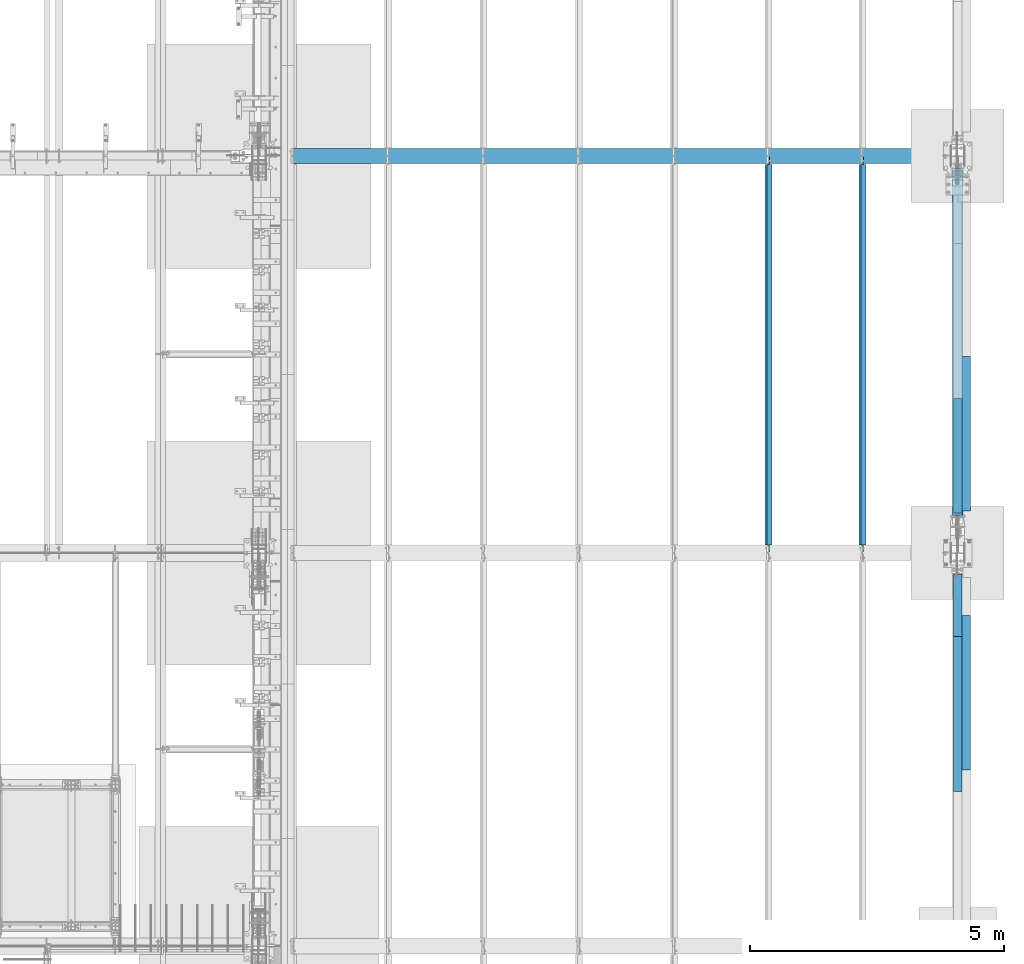
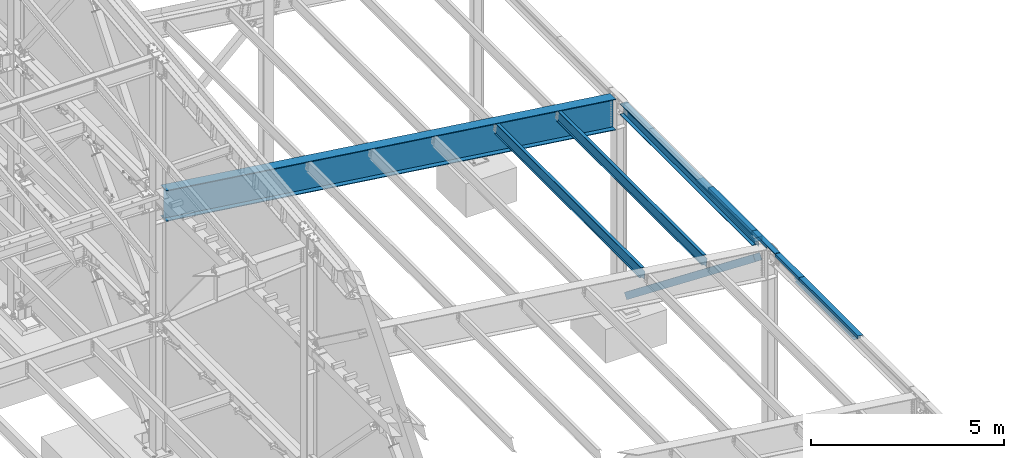
# One storey, part 750 of 1179: 10 beams, 1 member, 7 elements without a shape of their own.
"""IFC2X3 building model written with IfcOpenShell, lengths in millimetres."""

from ifc_helpers import new_model, si_unit, frame, origin_with_axes, place, context, subcontext, project, spatial, faceted_brep, material, type_object, element, aggregate, save


model = new_model("IFC2X3")

# Units and contexts
model_context = context("Model", 3, precision=1e-05, world=origin_with_axes())
body_context = subcontext(model_context, "Body", "Model", "MODEL_VIEW")
ifc_project = project(units=[si_unit("LENGTHUNIT", "METRE", prefix="MILLI"), si_unit("AREAUNIT", "SQUARE_METRE"), si_unit("VOLUMEUNIT", "CUBIC_METRE"), si_unit("MASSUNIT", "GRAM", prefix="KILO"), si_unit("TIMEUNIT", "SECOND"), si_unit("PLANEANGLEUNIT", "RADIAN"), si_unit("SOLIDANGLEUNIT", "STERADIAN"), si_unit("THERMODYNAMICTEMPERATUREUNIT", "DEGREE_CELSIUS"), si_unit("LUMINOUSINTENSITYUNIT", "LUMEN")], contexts=[model_context])

# Site, building, storey
site_placement = place(None, origin_with_axes())
site = spatial("IfcSite", under=ifc_project, at=site_placement, CompositionType="ELEMENT")
building_placement = place(site_placement, origin_with_axes())
building = spatial("IfcBuilding", under=site, at=building_placement, Name="Undefined", CompositionType="ELEMENT")
storey_placement = place(building_placement, origin_with_axes())
storey = spatial("IfcBuildingStorey", under=building, at=storey_placement, Name="Undefined", CompositionType="ELEMENT", Elevation=0.0)

# Assembly, beam
assembly_1_placement = place(storey_placement, origin_with_axes())
assembly_1 = element("IfcElementAssembly", 1, at=assembly_1_placement, inside=storey, Name="BENT_PLATE", AssemblyPlace="NOTDEFINED", PredefinedType="RIGID_FRAME")
ifc_material_1 = material(Name="STEEL/A36")
beam_type_1 = type_object("IfcBeamType", PredefinedType="NOTDEFINED")
beam_1_placement = place(assembly_1_placement, frame((37996.8124994167, 19419.1191790178, 6096.00000000004), z_axis=(0.0, -1.0, 0.0), x_axis=(0.0, 0.0, 1.0)))
beam_1 = element("IfcBeam", 2, at=beam_1_placement, type_object=beam_type_1, material=ifc_material_1, Name="BENT_PLATE", context=body_context, shape_type="Brep", body=[
    faceted_brep([(60.3249999999616, -160.337506103519, 173.062929017837), (60.3249999999616, -150.812506103524, 173.062929017837), (-7.6397554948926e-11, -150.812506103524, 173.062929017837), (-7.6397554948926e-11, -160.337506103519, 173.062929017837), (60.3249999999616, -160.337506103519, 584.200000000001), (60.3249999999616, -150.812506103524, 584.200000000001), (60.3249999999616, -4.76249999951688, 173.062929017837), (60.3249999999616, 4.76250000048458, 173.062929017837), (-3.8198777474463e-11, 4.76249999999709, 173.062929017837), (3.8198777474463e-11, -4.76249999999709, 173.062929017837), (60.3249999999616, -4.76249999951688, 584.200000000001), (60.3249999999616, 4.76250000048458, 584.200000000001), (62.266532833075, -150.812506103524, -584.200000000001), (81.9873102930469, -4.76249999933498, -584.200000000001), (3.8198777474463e-11, -4.76249999999709, -584.200000000001), (-3.8198777474463e-11, 4.76249999999709, -584.200000000001), (92.8848876952779, 4.76250000074651, -584.200000000001), (70.5918350219381, -160.337506103519, -584.200000000001), (-7.6397554948926e-11, -160.337506103519, -584.200000000001), (-7.6397554948926e-11, -150.812506103524, -584.200000000001), (62.266532833075, -150.812506103524, 584.200000000001), (81.9873102930469, -4.76249999933498, 584.200000000001), (92.8848876952779, 4.76250000074651, 584.200000000001), (70.5918350219381, -160.337506103519, 584.200000000001)], [[[0, 1, 2, 3]], [[4, 5, 1, 0]], [[6, 7, 8, 9]], [[10, 11, 7, 6]], [[12, 13, 14, 15, 16, 17, 18, 19]], [[19, 18, 3, 2]], [[20, 12, 19, 2, 1, 5]], [[21, 13, 12, 20]], [[9, 14, 13, 21, 10, 6]], [[15, 14, 9, 8]], [[22, 16, 15, 8, 7, 11]], [[16, 22, 23, 17]], [[3, 18, 17, 23, 4, 0]], [[23, 22, 11, 10, 21, 20, 5, 4]]]),
])
aggregate(assembly_1, [beam_1])

assembly_2_placement = place(storey_placement, origin_with_axes())
assembly_2 = element("IfcElementAssembly", 3, at=assembly_2_placement, inside=storey, Name="BEAM", AssemblyPlace="NOTDEFINED", PredefinedType="RIGID_FRAME")
beam_2_placement = place(assembly_2_placement, frame((37996.8124994166, 21146.3191790178, 6096.00000000004), z_axis=(0.0, -1.0, 0.0), x_axis=(0.0, 0.0, 1.0)))
beam_2 = element("IfcBeam", 4, at=beam_2_placement, type_object=beam_type_1, material=ifc_material_1, Name="BENT_PLATE", context=body_context, shape_type="Brep", body=[
    faceted_brep([(3.8198777474463e-11, -4.76249999999709, -1130.3), (3.8198777474463e-11, -4.76249999999709, 1130.3), (-3.8198777474463e-11, 4.76249999999709, 1130.3), (-3.8198777474463e-11, 4.76249999999709, -1130.3), (92.8848876952779, 4.76250000074651, 1130.3), (92.8848876952779, 4.76250000074651, -1130.3), (81.9873102930469, -4.76249999933498, -1130.3), (81.9873102930469, -4.76249999933498, 1130.3), (70.5918350219381, -160.337506103519, 1130.3), (70.5918350219381, -160.337506103519, -1130.3), (62.266532833075, -150.812506103524, -1130.3), (62.266532833075, -150.812506103524, 1130.3), (-7.6397554948926e-11, -160.337506103519, 1130.3), (-7.6397554948926e-11, -160.337506103519, -1130.3), (-7.6397554948926e-11, -150.812506103524, 1130.3), (-7.6397554948926e-11, -150.812506103524, -1130.3)], [[[0, 1, 2, 3]], [[3, 2, 4, 5]], [[1, 0, 6, 7]], [[5, 4, 8, 9]], [[7, 6, 10, 11]], [[9, 8, 12, 13]], [[8, 4, 2, 1, 7, 11, 14, 12]], [[11, 10, 15, 14]], [[10, 6, 0, 3, 5, 9, 13, 15]], [[14, 15, 13, 12]]]),
])

# Assembly, beams
assembly_3_placement = place(storey_placement, origin_with_axes())
assembly_3 = element("IfcElementAssembly", 5, at=assembly_3_placement, inside=storey, Name="BEAM", AssemblyPlace="NOTDEFINED", PredefinedType="RIGID_FRAME")
beam_3_placement = place(assembly_3_placement, frame((37996.8124994166, 18199.1, 6096.00000000004), z_axis=(0.0, -1.0, 0.0), x_axis=(0.0, 0.0, 1.0)))
beam_3 = element("IfcBeam", 6, at=beam_3_placement, type_object=beam_type_1, material=ifc_material_1, Name="BENT_PLATE", context=body_context, shape_type="Brep", body=[
    faceted_brep([(3.8198777474463e-11, -4.76249999999709, -619.125), (3.8198777474463e-11, -4.76249999999709, 619.125), (-3.8198777474463e-11, 4.76249999999709, 619.125), (-3.8198777474463e-11, 4.76249999999709, -619.125), (92.8848876952779, 4.76250000074651, 619.125), (92.8848876952779, 4.76250000074651, -619.125), (81.9873102930469, -4.76249999933498, -619.125), (81.9873102930469, -4.76249999933498, 619.125), (70.5918350219381, -160.337506103519, 619.125), (70.5918350219381, -160.337506103519, -619.125), (62.266532833075, -150.812506103524, -619.125), (62.266532833075, -150.812506103524, 619.125), (-7.6397554948926e-11, -160.337506103519, 619.125), (-7.6397554948926e-11, -160.337506103519, -619.125), (-7.6397554948926e-11, -150.812506103524, 619.125), (-7.6397554948926e-11, -150.812506103524, -619.125)], [[[0, 1, 2, 3]], [[3, 2, 4, 5]], [[1, 0, 6, 7]], [[5, 4, 8, 9]], [[7, 6, 10, 11]], [[9, 8, 12, 13]], [[8, 4, 2, 1, 7, 11, 14, 12]], [[11, 10, 15, 14]], [[10, 6, 0, 3, 5, 9, 13, 15]], [[14, 15, 13, 12]]]),
])
beam_4_placement = place(assembly_3_placement, frame((37996.8124994166, 16055.975, 6096.00000000004), z_axis=(0.0, -1.0, 0.0), x_axis=(0.0, 0.0, 1.0)))
beam_4 = element("IfcBeam", 7, at=beam_4_placement, type_object=beam_type_1, material=ifc_material_1, Name="BENT_PLATE", context=body_context, shape_type="Brep", body=[
    faceted_brep([(-2.91038304567337e-11, -4.76250000000073, -1524.0), (-2.91038304567337e-11, -4.76250000000073, 1524.0), (2.91038304567337e-11, 4.76250000000073, 1524.0), (2.91038304567337e-11, 4.76250000000073, -1524.0), (92.8848876952779, 4.76250000074651, 1524.0), (92.8848876952779, 4.76250000074651, -1524.0), (81.9873102930469, -4.76249999933498, -1524.0), (81.9873102930469, -4.76249999933498, 1524.0), (70.5918350219381, -160.337506103519, 1524.0), (70.5918350219381, -160.337506103519, -1524.0), (62.266532833075, -150.812506103524, -1524.0), (62.266532833075, -150.812506103524, 1524.0), (-7.6397554948926e-11, -160.337506103519, 1524.0), (-7.6397554948926e-11, -160.337506103519, -1524.0), (8.54161044117063e-08, -150.812499999749, 1524.0), (8.54161044117063e-08, -150.812499999749, -1524.0)], [[[0, 1, 2, 3]], [[3, 2, 4, 5]], [[1, 0, 6, 7]], [[5, 4, 8, 9]], [[7, 6, 10, 11]], [[9, 8, 12, 13]], [[8, 4, 2, 1, 7, 11, 14, 12]], [[11, 10, 15, 14]], [[10, 6, 0, 3, 5, 9, 13, 15]], [[14, 15, 13, 12]]]),
])

# Assembly, member
assembly_4_placement = place(storey_placement, origin_with_axes())
assembly_4 = element("IfcElementAssembly", 8, at=assembly_4_placement, inside=storey, Name="None", AssemblyPlace="NOTDEFINED", PredefinedType="RIGID_FRAME")
ifc_material_2 = material(Name="STEEL/A992")
member_type = type_object("IfcMemberType", Name="HSS8X8X3/16", PredefinedType="NOTDEFINED")
member_placement = place(assembly_4_placement, frame((38074.6, 26521.5643718268, 187.492569083372), z_axis=(-1.0, 0.0, 0.0), x_axis=(0.0, -0.786240824587351, 0.61792019367569)))
member = element("IfcMember", 9, at=member_placement, type_object=member_type, material=ifc_material_2, Name="None", ObjectType="HSS8X8X3/16", context=body_context, shape_type="Brep", body=[
    faceted_brep([(-3.63797880709171e-12, 96.8374999999978, -96.8375000000015), (-3.63797880709171e-12, -96.8374999999978, -96.8375000000015), (8464.54999991995, -96.8374999905063, -96.8375000000015), (8464.54999991995, 96.8375000094893, -96.8375000000015), (-3.63797880709171e-12, -96.8374999999978, 96.8375000000015), (8464.54999991995, -96.8374999905063, 96.8375000000015), (-3.63797880709171e-12, 96.8374999999978, 96.8375000000015), (8464.54999991995, 96.8375000094893, 96.8375000000015), (-3.63797880709171e-12, 101.599999999999, -101.599999999999), (-3.63797880709171e-12, 101.599999999999, 101.599999999999), (8464.54999991995, 101.60000000949, 101.599999999999), (8464.54999991995, 101.60000000949, -101.599999999999), (0.0, -101.599999999999, 101.599999999999), (8464.54999991995, -101.599999990503, 101.599999999999), (0.0, -101.599999999999, -101.599999999999), (8464.54999991995, -101.599999990503, -101.599999999999)], [[[0, 1, 2, 3]], [[1, 4, 5, 2]], [[4, 6, 7, 5]], [[6, 0, 3, 7]], [[8, 9, 10, 11]], [[9, 12, 13, 10]], [[12, 14, 15, 13]], [[14, 8, 11, 15]], [[13, 15, 11, 10], [5, 7, 3, 2]], [[14, 12, 9, 8], [6, 4, 1, 0]]]),
])
aggregate(assembly_4, [member])

# Beam
beam_type_2 = type_object("IfcBeamType", PredefinedType="NOTDEFINED")
beam_5_placement = place(assembly_3_placement, frame((38112.7, 16476.6625000003, 5765.8), z_axis=(0.0, 1.0, 0.0), x_axis=(1.0, 0.0, 0.0)))
beam_5 = element("IfcBeam", 10, at=beam_5_placement, type_object=beam_type_2, material=ifc_material_1, Name="BENT_PLATE", context=body_context, shape_type="Brep", body=[
    faceted_brep([(0.0, -3.17499999999927, -1524.0), (6.00266503170133e-10, -3.17499999922438, 1524.00000000052), (6.00266503170133e-10, 3.17500000077416, 1524.00000000052), (0.0, 3.17499999999927, -1524.0), (215.900000000009, 3.17500000000018, 1524.0), (215.900000000009, 3.17500000000018, -1524.0), (209.550000000003, -3.17500000000018, -1524.0), (209.550000000003, -3.17500000000018, 1524.0), (215.900000000009, -123.825, 1524.0), (215.900000000009, -123.825, -1524.0), (209.550000000003, -117.474999999999, -1524.0), (209.550000000003, -117.474999999999, 1524.0), (-34.1312499999985, -123.825, 1524.0), (-34.1312499999985, -123.825, -1524.0), (-34.1312499999985, -117.474999999999, 1524.0), (-34.1312499999985, -117.474999999999, -1524.0)], [[[0, 1, 2, 3]], [[3, 2, 4, 5]], [[1, 0, 6, 7]], [[5, 4, 8, 9]], [[7, 6, 10, 11]], [[9, 8, 12, 13]], [[8, 4, 2, 1, 7, 11, 14, 12]], [[11, 10, 15, 14]], [[10, 6, 0, 3, 5, 9, 13, 15]], [[14, 15, 13, 12]]]),
])

aggregate(assembly_3, [beam_5, beam_3, beam_4])

beam_6_placement = place(assembly_2_placement, frame((38113.49375, 21579.5611179414, 5764.21250000249), z_axis=(0.0, 1.0, 0.0), x_axis=(1.0, 0.0, 0.0)))
beam_6 = element("IfcBeam", 11, at=beam_6_placement, type_object=beam_type_2, material=ifc_material_1, Name="BENT_PLATE", context=body_context, shape_type="Brep", body=[
    faceted_brep([(0.0, -3.17499999999927, -1524.0), (6.00266503170133e-10, -3.17499999922438, 1524.00000000052), (6.00266503170133e-10, 3.17500000077416, 1524.00000000052), (0.0, 3.17499999999927, -1524.0), (215.900000000009, 3.17500000000018, 1524.0), (215.900000000009, 3.17500000000018, -1524.0), (209.550000000003, -3.17500000000018, -1524.0), (209.550000000003, -3.17500000000018, 1524.0), (215.900000000009, -123.825, 1524.0), (215.900000000009, -123.825, -1524.0), (209.550000000003, -117.474999999999, -1524.0), (209.550000000003, -117.474999999999, 1524.0), (-34.1312499999985, -123.825, 1524.0), (-34.1312499999985, -123.825, -1524.0), (-34.1312499999985, -117.474999999999, 1524.0), (-34.1312499999985, -117.474999999999, -1524.0)], [[[0, 1, 2, 3]], [[3, 2, 4, 5]], [[1, 0, 6, 7]], [[5, 4, 8, 9]], [[7, 6, 10, 11]], [[9, 8, 12, 13]], [[8, 4, 2, 1, 7, 11, 14, 12]], [[11, 10, 15, 14]], [[10, 6, 0, 3, 5, 9, 13, 15]], [[14, 15, 13, 12]]]),
])

# Assembly, beam
assembly_5_placement = place(storey_placement, origin_with_axes())
assembly_5 = element("IfcElementAssembly", 12, at=assembly_5_placement, inside=storey, Name="BEAM", AssemblyPlace="NOTDEFINED", PredefinedType="RIGID_FRAME")
beam_type_3 = type_object("IfcBeamType", Name="W12X22", PredefinedType="NOTDEFINED")
beam_7_placement = place(assembly_5_placement, frame((36199.5820076836, 19227.8, 6273.93066543799), z_axis=(0.133813223953133, 0.0, 0.991006569652931), x_axis=(0.0, 1.0, 0.0)))
beam_7 = element("IfcBeam", 13, at=beam_7_placement, type_object=beam_type_3, material=ifc_material_2, Name="BEAM", ObjectType="W12X22", context=body_context, shape_type="Brep", body=[
    faceted_brep([(7661.27499999999, -3.17499999982829, -144.462500000049), (7661.27499999999, -50.7999999998501, -144.462500000061), (7661.27499999999, -50.7999999998283, -155.575000000066), (7661.27499999999, 50.8000000001921, -155.575000000039), (7661.27499999999, 50.8000000001775, -144.462500000034), (7661.27499999999, 3.17500000017026, -144.462500000049), (7661.27499999999, 3.17500000016298, -136.524999801411), (7661.27499999999, -3.17499999984284, -136.524999801408), (7662.24172992258, 3.17500000015571, -131.664920283361), (7662.24172992258, -3.17499999984284, -131.664920283358), (7664.99474382306, 3.17500000014843, -127.544743815204), (7664.99474382306, -3.17499999985012, -127.5447438152), (7669.11492029121, 3.17500000015571, -124.791729914723), (7669.11492029121, -3.17499999985012, -124.791729914719), (7673.97499980926, 3.17500000014115, -123.824999992134), (7673.97499980926, -3.17499999985739, -123.82499999213), (7802.5625, -3.17499999985739, -123.824999992026), (7802.5625, 3.17500000014115, -123.824999992017), (161.925000000007, 3.17499999983556, 144.462500000051), (161.925000000007, 50.7999999998428, 144.462500000063), (7661.275, 50.7999999998356, 144.462500000063), (7661.275, 3.17499999982829, 144.462500000051), (161.925000000007, -3.17499999984284, -136.524999799629), (161.925000000007, 3.17500000016298, -136.524999799632), (161.925000000007, 3.17500000017026, -144.462500000049), (161.925000000007, 50.8000000001775, -144.462500000034), (161.925000000007, 50.8000000001994, -155.575000000039), (161.925000000007, -50.7999999998283, -155.575000000066), (161.925000000007, -50.7999999998428, -144.462500000063), (161.925000000007, -3.17499999982101, -144.462500000049), (160.958270077419, -3.17499999984284, -131.664920281577), (160.958270077419, 3.17500000015571, -131.664920281581), (158.205256176941, -3.17499999984284, -127.54474381342), (158.205256176941, 3.17500000014843, -127.544743813425), (154.085079708788, -3.17499999985012, -124.791729912939), (154.085079708788, 3.17500000015571, -124.791729912944), (149.225000190741, -3.17499999985012, -123.824999990349), (149.225000190741, 3.17500000014115, -123.824999990355), (20.6375000000044, -3.17499999985739, -123.824999990466), (20.6375000000044, 3.17500000014843, -123.824999990458), (20.6375000000044, -3.17500000014115, 117.475000009781), (20.6375000000044, 3.17499999986467, 117.475000009788), (149.225000190741, -3.17500000014115, 117.475000009897), (149.225000190741, 3.17499999986467, 117.475000009894), (154.085079708788, -3.17500000014115, 118.441729932485), (154.085079708788, 3.17499999986467, 118.441729932481), (158.205256176941, -3.17500000014843, 121.194743832966), (158.205256176941, 3.17499999985739, 121.194743832963), (160.958270077419, -3.17500000014843, 125.314920301123), (160.958270077419, 3.17499999985739, 125.31492030112), (161.925000000007, -3.17500000014843, 130.174999819174), (161.925000000007, 3.17499999985012, 130.17499981917), (161.925000000007, -50.8000000001994, 155.575000000041), (161.925000000007, 50.7999999998356, 155.575000000066), (161.925000000007, -3.17500000017026, 144.462500000049), (161.925000000007, -50.8000000001775, 144.462500000034), (7661.275, -3.17500000017753, 144.462500000049), (7661.275, -50.8000000001775, 144.462500000034), (7661.275, -50.8000000001994, 155.575000000041), (7661.275, 50.7999999998283, 155.575000000068), (7661.275, -3.17500000016298, 130.174999817395), (7661.275, 3.17499999985012, 130.174999817391), (7662.24172992259, -3.17500000015571, 125.314920299345), (7662.24172992259, 3.17499999985012, 125.314920299341), (7664.99474382306, -3.17500000014843, 121.194743831187), (7664.99474382306, 3.17499999985739, 121.194743831182), (7669.11492029122, -3.17500000014115, 118.441729930706), (7669.11492029122, 3.17499999986467, 118.441729930701), (7673.97499980926, -3.17500000014115, 117.475000008115), (7673.97499980926, 3.17499999986467, 117.475000008111), (7802.5625, -3.17500000014115, 117.47500000822), (7802.5625, 3.17499999985739, 117.475000008229)], [[[0, 1, 2, 3, 4, 5, 6, 7]], [[7, 6, 8, 9]], [[9, 8, 10, 11]], [[11, 10, 12, 13]], [[13, 12, 14, 15]], [[16, 15, 14, 17]], [[18, 19, 20, 21]], [[22, 23, 24, 25, 26, 27, 28, 29]], [[30, 31, 23, 22]], [[32, 33, 31, 30]], [[34, 35, 33, 32]], [[36, 37, 35, 34]], [[38, 39, 37, 36]], [[40, 41, 39, 38]], [[42, 43, 41, 40]], [[44, 45, 43, 42]], [[46, 47, 45, 44]], [[48, 49, 47, 46]], [[50, 51, 49, 48]], [[52, 53, 19, 18, 51, 50, 54, 55]], [[55, 54, 56, 57]], [[52, 55, 57, 58]], [[53, 52, 58, 59]], [[19, 53, 59, 20]], [[58, 57, 56, 60, 61, 21, 20, 59]], [[62, 63, 61, 60]], [[64, 65, 63, 62]], [[66, 67, 65, 64]], [[68, 69, 67, 66]], [[70, 71, 69, 68]], [[71, 70, 16, 17]], [[12, 10, 8, 6, 5, 24, 23, 31, 33, 35, 37, 39, 41, 43, 45, 47, 49, 51, 18, 21, 61, 63, 65, 67, 69, 71, 17, 14]], [[25, 24, 5, 4]], [[26, 25, 4, 3]], [[27, 26, 3, 2]], [[28, 27, 2, 1]], [[29, 28, 1, 0]], [[70, 68, 66, 64, 62, 60, 56, 54, 50, 48, 46, 44, 42, 40, 38, 36, 34, 32, 30, 22, 29, 0, 7, 9, 11, 13, 15, 16]]]),
])
aggregate(assembly_5, [beam_7])

assembly_6_placement = place(storey_placement, origin_with_axes())
assembly_6 = element("IfcElementAssembly", 14, at=assembly_6_placement, inside=storey, Name="BEAM", AssemblyPlace="NOTDEFINED", PredefinedType="RIGID_FRAME")
beam_8_placement = place(assembly_6_placement, frame((34345.3820076835, 19227.8, 6524.29881379359), z_axis=(0.133813223953133, 0.0, 0.991006569652931), x_axis=(0.0, 1.0, 0.0)))
beam_8 = element("IfcBeam", 15, at=beam_8_placement, type_object=beam_type_3, material=ifc_material_2, Name="BEAM", ObjectType="W12X22", context=body_context, shape_type="Brep", body=[
    faceted_brep([(7661.27499999999, -3.17499999982829, -144.462500000049), (7661.27499999999, -50.7999999998501, -144.462500000061), (7661.27499999999, -50.7999999998283, -155.575000000066), (7661.27499999999, 50.8000000001921, -155.575000000039), (7661.27499999999, 50.8000000001775, -144.462500000034), (7661.27499999999, 3.17500000017026, -144.462500000049), (7661.27499999999, 3.17500000016298, -136.524999801411), (7661.27499999999, -3.17499999984284, -136.524999801408), (7662.24172992258, 3.17500000015571, -131.664920283361), (7662.24172992258, -3.17499999984284, -131.664920283358), (7664.99474382306, 3.17500000014843, -127.544743815204), (7664.99474382306, -3.17499999985012, -127.5447438152), (7669.11492029121, 3.17500000015571, -124.791729914723), (7669.11492029121, -3.17499999985012, -124.791729914719), (7673.97499980926, 3.17500000014115, -123.824999992134), (7673.97499980926, -3.17499999985739, -123.82499999213), (7802.5625, -3.17499999985739, -123.824999992026), (7802.5625, 3.17500000014115, -123.824999992017), (161.925000000007, 3.17499999983556, 144.462500000051), (161.925000000007, 50.7999999998428, 144.462500000063), (7661.275, 50.7999999998356, 144.462500000063), (7661.275, 3.17499999982829, 144.462500000051), (161.925000000007, -3.17499999984284, -136.524999799629), (161.925000000007, 3.17500000016298, -136.524999799632), (161.925000000007, 3.17500000017026, -144.462500000049), (161.925000000007, 50.8000000001775, -144.462500000034), (161.925000000007, 50.8000000001994, -155.575000000039), (161.925000000007, -50.7999999998283, -155.575000000066), (161.925000000007, -50.7999999998428, -144.462500000063), (161.925000000007, -3.17499999982101, -144.462500000049), (160.958270077419, -3.17499999984284, -131.664920281577), (160.958270077419, 3.17500000015571, -131.664920281581), (158.205256176941, -3.17499999984284, -127.54474381342), (158.205256176941, 3.17500000014843, -127.544743813425), (154.085079708788, -3.17499999985012, -124.791729912939), (154.085079708788, 3.17500000015571, -124.791729912944), (149.225000190741, -3.17499999985012, -123.824999990349), (149.225000190741, 3.17500000014115, -123.824999990355), (20.6375000000044, -3.17499999985739, -123.824999990466), (20.6375000000044, 3.17500000014843, -123.824999990458), (20.6375000000044, -3.17500000014115, 117.475000009781), (20.6375000000044, 3.17499999986467, 117.475000009788), (149.225000190741, -3.17500000014115, 117.475000009897), (149.225000190741, 3.17499999986467, 117.475000009894), (154.085079708788, -3.17500000014115, 118.441729932485), (154.085079708788, 3.17499999986467, 118.441729932481), (158.205256176941, -3.17500000014843, 121.194743832966), (158.205256176941, 3.17499999985739, 121.194743832963), (160.958270077419, -3.17500000014843, 125.314920301123), (160.958270077419, 3.17499999985739, 125.31492030112), (161.925000000007, -3.17500000014843, 130.174999819174), (161.925000000007, 3.17499999985012, 130.17499981917), (161.925000000007, -50.8000000001994, 155.575000000041), (161.925000000007, 50.7999999998356, 155.575000000066), (161.925000000007, -3.17500000017026, 144.462500000049), (161.925000000007, -50.8000000001775, 144.462500000034), (7661.275, -3.17500000017753, 144.462500000049), (7661.275, -50.8000000001775, 144.462500000034), (7661.275, -50.8000000001994, 155.575000000041), (7661.275, 50.7999999998283, 155.575000000068), (7661.275, -3.17500000016298, 130.174999817395), (7661.275, 3.17499999985012, 130.174999817391), (7662.24172992259, -3.17500000015571, 125.314920299345), (7662.24172992259, 3.17499999985012, 125.314920299341), (7664.99474382306, -3.17500000014843, 121.194743831187), (7664.99474382306, 3.17499999985739, 121.194743831182), (7669.11492029122, -3.17500000014115, 118.441729930706), (7669.11492029122, 3.17499999986467, 118.441729930701), (7673.97499980926, -3.17500000014115, 117.475000008115), (7673.97499980926, 3.17499999986467, 117.475000008111), (7802.5625, -3.17500000014115, 117.47500000822), (7802.5625, 3.17499999985739, 117.475000008229)], [[[0, 1, 2, 3, 4, 5, 6, 7]], [[7, 6, 8, 9]], [[9, 8, 10, 11]], [[11, 10, 12, 13]], [[13, 12, 14, 15]], [[16, 15, 14, 17]], [[18, 19, 20, 21]], [[22, 23, 24, 25, 26, 27, 28, 29]], [[30, 31, 23, 22]], [[32, 33, 31, 30]], [[34, 35, 33, 32]], [[36, 37, 35, 34]], [[38, 39, 37, 36]], [[40, 41, 39, 38]], [[42, 43, 41, 40]], [[44, 45, 43, 42]], [[46, 47, 45, 44]], [[48, 49, 47, 46]], [[50, 51, 49, 48]], [[52, 53, 19, 18, 51, 50, 54, 55]], [[55, 54, 56, 57]], [[52, 55, 57, 58]], [[53, 52, 58, 59]], [[19, 53, 59, 20]], [[58, 57, 56, 60, 61, 21, 20, 59]], [[62, 63, 61, 60]], [[64, 65, 63, 62]], [[66, 67, 65, 64]], [[68, 69, 67, 66]], [[70, 71, 69, 68]], [[71, 70, 16, 17]], [[12, 10, 8, 6, 5, 24, 23, 31, 33, 35, 37, 39, 41, 43, 45, 47, 49, 51, 18, 21, 61, 63, 65, 67, 69, 71, 17, 14]], [[25, 24, 5, 4]], [[26, 25, 4, 3]], [[27, 26, 3, 2]], [[28, 27, 2, 1]], [[29, 28, 1, 0]], [[70, 68, 66, 64, 62, 60, 56, 54, 50, 48, 46, 44, 42, 40, 38, 36, 34, 32, 30, 22, 29, 0, 7, 9, 11, 13, 15, 16]]]),
])
aggregate(assembly_6, [beam_8])

assembly_7_placement = place(storey_placement, origin_with_axes())
assembly_7 = element("IfcElementAssembly", 16, at=assembly_7_placement, inside=storey, Name="BEAM", AssemblyPlace="NOTDEFINED", PredefinedType="RIGID_FRAME")
beam_type_4 = type_object("IfcBeamType", Name="W40X149", PredefinedType="NOTDEFINED")
beam_9_placement = place(assembly_7_placement, frame((24242.796881036, 27051.0, 7555.22990682014), z_axis=(0.133813223953133, 0.0, 0.991006569652931), x_axis=(0.99100656965293, 0.0, -0.133813223953134)))
beam_9 = element("IfcBeam", 17, at=beam_9_placement, type_object=beam_type_4, material=ifc_material_2, Name="BEAM", ObjectType="W40X149", context=body_context, shape_type="Brep", body=[
    faceted_brep([(302.590061503044, -149.224999999999, -485.775000000245), (302.590061503044, 149.224999999999, -485.775000000245), (13853.1182925061, 149.224999999999, -485.775000003989), (13853.1182925061, -149.224999999999, -485.775000003989), (299.803429714837, -149.224999999999, -465.137500000239), (299.803429714837, -7.9375, -465.137500000239), (174.190642954203, -7.9375, 465.137500000114), (174.190642954203, -149.224999999999, 465.137500000114), (171.404011165996, -149.224999999999, 485.77500000012), (171.404011165996, 149.224999999999, 485.77500000012), (174.190642954203, 149.224999999999, 465.137500000114), (174.190642954203, 7.9375, 465.137500000114), (299.803429714837, 7.9375, -465.137500000239), (299.803429714837, 149.224999999999, -465.137500000239), (13850.3316607179, -149.224999999999, -465.137500003979), (13850.3316607179, -7.9375, -465.137500003979), (13724.7188739573, -7.9375, 465.137499996372), (13724.7188739573, -149.224999999999, 465.137499996372), (13721.9322421691, -149.224999999999, 485.774999996378), (13721.9322421691, 149.224999999999, 485.774999996378), (13724.7188739573, 149.224999999999, 465.137499996372), (13724.7188739573, 7.9375, 465.137499996372), (13850.3316607179, 7.9375, -465.137500003979), (13850.3316607179, 149.224999999999, -465.137500003979)], [[[0, 1, 2, 3]], [[0, 4, 5, 6, 7, 8, 9, 10, 11, 12, 13, 1]], [[5, 4, 14, 15]], [[6, 5, 15, 16]], [[7, 6, 16, 17]], [[8, 7, 17, 18]], [[9, 8, 18, 19]], [[10, 9, 19, 20]], [[11, 10, 20, 21]], [[12, 11, 21, 22]], [[13, 12, 22, 23]], [[1, 13, 23, 2]], [[22, 21, 20, 19, 18, 17, 16, 15, 14, 3, 2, 23]], [[4, 0, 3, 14]]]),
])
aggregate(assembly_7, [beam_9])

# Beam
beam_type_5 = type_object("IfcBeamType", Name="W14X53", PredefinedType="NOTDEFINED")
beam_10_placement = place(assembly_2_placement, frame((38074.6, 19227.8, 5919.7875), z_axis=(0.0, 0.0, 1.0), x_axis=(0.0, 1.0, 0.0)))
beam_10 = element("IfcBeam", 18, at=beam_10_placement, type_object=beam_type_5, material=ifc_material_2, Name="BEAM", ObjectType="W14X53", context=body_context, shape_type="Brep", body=[
    faceted_brep([(737.419179017841, -101.599999999999, 176.2125), (737.419179017841, 101.599999999999, 176.2125), (727.337562189616, 101.599999999999, 158.75), (727.337562189616, 4.76249999999709, 158.75), (727.108362368235, 4.76249999999709, 158.353), (727.108362368235, -4.76249999999709, 158.353), (727.337562189616, -4.76249999999709, 158.75), (727.337562189616, -101.599999999999, 158.75), (770.200578660595, -4.76249999999709, 158.353), (770.200578660595, 4.76249999999709, 158.353), (784.776942857599, 4.76249999999709, 151.493356973128), (784.776942857599, -4.76249999999709, 151.493356973128), (788.632691466646, 4.76249999999709, 148.179052423035), (788.632691466646, -4.76249999999709, 148.179052423035), (790.234117941396, 4.76249999999709, 143.353407882364), (790.234117941396, -4.76249999999709, 143.353407882364), (789.124910860664, 4.76249999999709, 138.391445403769), (789.124910860664, -4.76249999999709, 138.391445403769), (785.621128355982, 4.76249999999709, 134.707029554976), (785.621128355982, -4.76249999999709, 134.707029554976), (780.721140317848, 4.76249999999709, 133.35), (780.721140317848, -4.76249999999709, 133.35), (578.112578660595, 4.76249999999709, 133.35), (578.112578660595, -4.76249999999709, 133.35), (578.112578660595, 4.76249999999709, -133.35), (578.112578660595, -4.76249999999709, -133.35), (780.148140317848, 4.76249999999709, -133.35), (780.148140317848, -4.76249999999709, -133.35), (785.048128355982, 4.76249999999709, -134.707029554975), (785.048128355982, -4.76249999999709, -134.707029554975), (788.551910860664, 4.76249999999709, -138.391445403768), (788.551910860664, -4.76249999999709, -138.391445403768), (789.661117941396, 4.76249999999709, -143.353407882363), (789.661117941396, -4.76249999999709, -143.353407882363), (788.059691466646, 4.76249999999709, -148.179052423034), (788.059691466646, -4.76249999999709, -148.179052423034), (784.203942857599, 4.76249999999709, -151.493356973128), (784.203942857599, -4.76249999999709, -151.493356973128), (769.627578660595, 4.76249999999709, -158.353), (769.627578660595, -4.76249999999709, -158.353), (737.648387510755, 4.76249999999709, -158.353), (737.648387510755, -4.76249999999709, -158.353), (7577.13749999999, 4.76249999999709, -158.75), (7577.13749999999, 101.599999999999, -158.75), (737.419196360916, 101.599999999999, -158.75), (737.419196360916, 4.76249999999709, -158.75), (7577.13749999999, 101.599999999999, -176.2125), (7577.13749999999, -101.599999999999, -176.2125), (727.337960960274, -101.599999999999, -176.2125), (727.337960960274, 101.599999999999, -176.2125), (7577.13749999999, -101.599999999999, -158.75), (737.419196360916, -101.599999999999, -158.75), (7577.13749999999, -4.76249999999709, -158.75), (737.419196360916, -4.76249999999709, -158.75), (7577.13749999999, 4.76249999999709, -103.927499821131), (7577.13749999999, 4.76249999999709, 126.152500178652), (7577.13749999999, 4.76249999999709, 158.75), (7577.13749999999, 101.599999999999, 158.75), (7577.13749999999, 101.599999999999, 176.2125), (7577.13749999999, -101.599999999999, 176.2125), (7577.13749999999, -101.599999999999, 158.75), (7577.13749999999, -4.76249999999709, 158.75)], [[[0, 1, 2, 3, 4, 5, 6, 7]], [[8, 9, 10, 11]], [[11, 10, 12, 13]], [[13, 12, 14, 15]], [[15, 14, 16, 17]], [[17, 16, 18, 19]], [[19, 18, 20, 21]], [[21, 20, 22, 23]], [[23, 22, 24, 25]], [[26, 27, 25, 24]], [[27, 26, 28, 29]], [[29, 28, 30, 31]], [[31, 30, 32, 33]], [[33, 32, 34, 35]], [[35, 34, 36, 37]], [[37, 36, 38, 39]], [[39, 38, 40, 41]], [[42, 43, 44, 45]], [[46, 47, 48, 49]], [[47, 50, 51, 48]], [[50, 52, 53, 51]], [[41, 40, 45, 44, 49, 48, 51, 53]], [[43, 46, 49, 44]], [[42, 54, 55, 56, 57, 58, 59, 60, 61, 52, 50, 47, 46, 43]], [[60, 59, 0, 7]], [[61, 60, 7, 6]], [[8, 11, 13, 15, 17, 19, 21, 23, 25, 27, 29, 31, 33, 35, 37, 39, 41, 53, 52, 61, 6, 5]], [[9, 8, 5, 4]], [[56, 55, 54, 42, 45, 40, 38, 36, 34, 32, 30, 28, 26, 24, 22, 20, 18, 16, 14, 12, 10, 9, 4, 3]], [[57, 56, 3, 2]], [[58, 57, 2, 1]], [[59, 58, 1, 0]]]),
])

aggregate(assembly_2, [beam_6, beam_2, beam_10])

save(model, "model.ifc")
